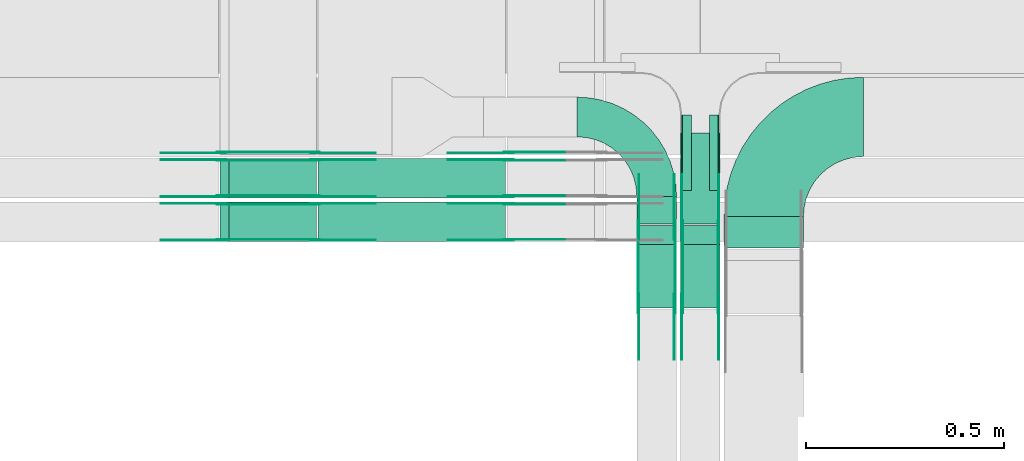
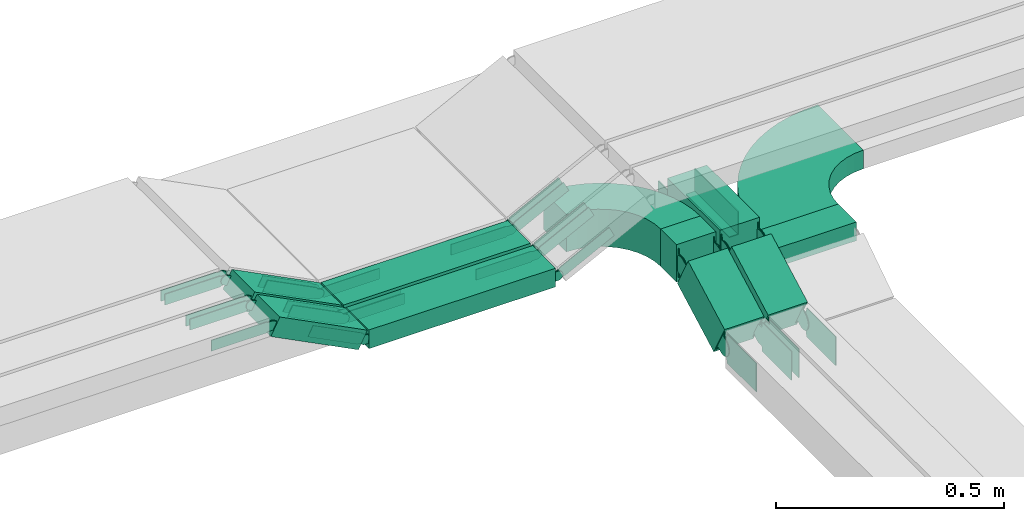
# One storey, part 22 of 28: 50 flow fittings, 9 flow segments.
"""IFC2X3 building model written with IfcOpenShell, lengths in millimetres."""

from ifc_helpers import new_model, entity, si_unit, converted_unit, derived_unit, direction, frame, frame_2d, origin, origin_2d_with_axis, place, context, subcontext, project, spatial, polyline, circle_curve, parameter, trimmed, segment, composite_curve, rectangle, outline, extrude, source, transform, mapped, material, type_object, type_shapes, element, save


model = new_model("IFC2X3")

# Units and contexts
model_context = context("Model", 3, precision=0.01, world=origin(), true_north=direction((6.12303176911189e-17, 1.0)))
body_context = subcontext(model_context, "Body", "Model", "MODEL_VIEW")
ifc_project = project(units=[si_unit("LENGTHUNIT", "METRE", prefix="MILLI"), si_unit("AREAUNIT", "SQUARE_METRE"), si_unit("VOLUMEUNIT", "CUBIC_METRE"), converted_unit("PLANEANGLEUNIT", "DEGREE", entity("IfcRatioMeasure", 0.0174532925199433), si_unit("PLANEANGLEUNIT", "RADIAN"), dimensions=[0, 0, 0, 0, 0, 0, 0]), si_unit("MASSUNIT", "GRAM", prefix="KILO"), derived_unit("MASSDENSITYUNIT", [(si_unit("MASSUNIT", "GRAM", prefix="KILO"), 1), (si_unit("LENGTHUNIT", "METRE"), -3)]), derived_unit("MOMENTOFINERTIAUNIT", [(si_unit("LENGTHUNIT", "METRE"), 4)]), si_unit("TIMEUNIT", "SECOND"), si_unit("FREQUENCYUNIT", "HERTZ"), si_unit("THERMODYNAMICTEMPERATUREUNIT", "DEGREE_CELSIUS"), derived_unit("THERMALTRANSMITTANCEUNIT", [(si_unit("MASSUNIT", "GRAM", prefix="KILO"), 1), (si_unit("THERMODYNAMICTEMPERATUREUNIT", "KELVIN"), -1), (si_unit("TIMEUNIT", "SECOND"), -3)]), derived_unit("VOLUMETRICFLOWRATEUNIT", [(si_unit("LENGTHUNIT", "METRE"), 3), (si_unit("TIMEUNIT", "SECOND"), -1)]), derived_unit("MASSFLOWRATEUNIT", [(si_unit("MASSUNIT", "GRAM", prefix="KILO"), 1), (si_unit("TIMEUNIT", "SECOND"), -1)]), derived_unit("ROTATIONALFREQUENCYUNIT", [(si_unit("TIMEUNIT", "SECOND"), -1)]), si_unit("ELECTRICCURRENTUNIT", "AMPERE"), si_unit("ELECTRICVOLTAGEUNIT", "VOLT"), si_unit("POWERUNIT", "WATT"), si_unit("FORCEUNIT", "NEWTON", prefix="KILO"), si_unit("ILLUMINANCEUNIT", "LUX"), si_unit("LUMINOUSFLUXUNIT", "LUMEN"), si_unit("LUMINOUSINTENSITYUNIT", "CANDELA"), derived_unit("USERDEFINED", [(si_unit("MASSUNIT", "GRAM", prefix="KILO"), -1), (si_unit("LENGTHUNIT", "METRE"), -2), (si_unit("TIMEUNIT", "SECOND"), 3), (si_unit("LUMINOUSFLUXUNIT", "LUMEN"), 1)]), derived_unit("LINEARVELOCITYUNIT", [(si_unit("LENGTHUNIT", "METRE"), 1), (si_unit("TIMEUNIT", "SECOND"), -1)]), si_unit("PRESSUREUNIT", "PASCAL"), derived_unit("USERDEFINED", [(si_unit("LENGTHUNIT", "METRE"), -2), (si_unit("MASSUNIT", "GRAM", prefix="KILO"), 1), (si_unit("TIMEUNIT", "SECOND"), -2)]), derived_unit("LINEARFORCEUNIT", [(si_unit("MASSUNIT", "GRAM", prefix="KILO"), 1), (si_unit("LENGTHUNIT", "METRE"), 1), (si_unit("TIMEUNIT", "SECOND"), -2), (si_unit("LENGTHUNIT", "METRE"), -1)]), derived_unit("PLANARFORCEUNIT", [(si_unit("MASSUNIT", "GRAM", prefix="KILO"), 1), (si_unit("LENGTHUNIT", "METRE"), 1), (si_unit("TIMEUNIT", "SECOND"), -2), (si_unit("LENGTHUNIT", "METRE"), -2)])], contexts=[model_context])

# Site, building, storey
site_placement = place(None, frame((0.0, -0.00077364408347762, 0.0)))
site = spatial("IfcSite", under=ifc_project, at=site_placement, CompositionType="ELEMENT")
building_placement = place(site_placement, origin())
building = spatial("IfcBuilding", under=site, at=building_placement, CompositionType="ELEMENT")
storey_placement = place(building_placement, origin())
storey = spatial("IfcBuildingStorey", under=building, at=storey_placement, CompositionType="ELEMENT", Elevation=0.0)

# Flow segments
cable_carrier_segment_type = type_object("IfcCableCarrierSegmentType", PredefinedType="CABLETRAYSEGMENT")
flow_segment_1_placement = place(storey_placement, frame((66224.9973266601, 8344.22814320413, 2600.0)))
element("IfcFlowSegment", 1, at=flow_segment_1_placement, inside=storey, type_object=cable_carrier_segment_type, context=body_context, shape_type="SweptSolid", body=[
    extrude(rectangle(XDim=69.0994138155711, YDim=99.9999999999946, at=origin_2d_with_axis()), frame((50.0, 34.5497069077856, 0.0), z_axis=(0.0, 0.0, 1.0), x_axis=(0.0, -1.0, 0.0)), (0.0, 0.0, 1.0), 100.0),
])
flow_segment_2_placement = place(storey_placement, frame((66224.9973266601, 8133.28255299691, 2512.93349487687)))
element("IfcFlowSegment", 2, at=flow_segment_2_placement, inside=storey, type_object=cable_carrier_segment_type, context=body_context, shape_type="SweptSolid", body=[
    extrude(rectangle(XDim=100.0, YDim=99.9999999999946, at=origin_2d_with_axis()), frame((50.0, 23.7298776139367, 44.0101455170004), z_axis=(0.0, 0.880202910340005, 0.474597552278754), x_axis=(0.0, -0.474597552278754, 0.880202910340005)), (0.0, 0.0, 1.0), 181.443664845643),
])
flow_segment_3_placement = place(storey_placement, frame((66334.9973266601, 8344.22814320465, 2600.0)))
element("IfcFlowSegment", 3, at=flow_segment_3_placement, inside=storey, type_object=cable_carrier_segment_type, context=body_context, shape_type="SweptSolid", body=[
    extrude(rectangle(XDim=230.099413815084, YDim=99.9999999999946, at=origin_2d_with_axis()), frame((50.0, 115.049706907542, 0.0), z_axis=(0.0, 0.0, 1.0), x_axis=(0.0, -1.0, 0.0)), (0.0, 0.0, 1.0), 100.0),
])
flow_segment_4_placement = place(storey_placement, frame((66334.9973266601, 8133.28255299713, 2512.93349487673)))
element("IfcFlowSegment", 4, at=flow_segment_4_placement, inside=storey, type_object=cable_carrier_segment_type, context=body_context, shape_type="SweptSolid", body=[
    extrude(rectangle(XDim=99.9999999999998, YDim=99.9999999999946, at=frame_2d((4.9382720135327e-13, 0.0), x_axis=(1.0, 0.0))), frame((50.0, 23.7298776137104, 44.0101455171233), z_axis=(0.0, 0.880202910342462, 0.474597552274198), x_axis=(0.0, -0.474597552274198, 0.880202910342462)), (0.0, 0.0, 1.0), 181.443664845729),
])
flow_segment_5_placement = place(storey_placement, frame((66444.9973266601, 8284.1246974401, 2600.0)))
element("IfcFlowSegment", 5, at=flow_segment_5_placement, inside=storey, type_object=cable_carrier_segment_type, context=body_context, shape_type="SweptSolid", body=[
    extrude(rectangle(XDim=79.2028595795973, YDim=200.000000000007, at=origin_2d_with_axis()), frame((100.0, 39.6014297898203, 0.0), z_axis=(0.0, 0.0, 1.0), x_axis=(0.0, -1.0, 0.0)), (0.0, 0.0, 1.0), 49.9999999999995),
])
flow_segment_6_placement = place(storey_placement, frame((65421.7807105328, 8300.00006103516, 2730.0)))
element("IfcFlowSegment", 6, at=flow_segment_6_placement, inside=storey, type_object=cable_carrier_segment_type, context=body_context, shape_type="SweptSolid", body=[
    extrude(rectangle(XDim=472.037715986993, YDim=100.000000000001, at=frame_2d((8.65441052155802e-12, 0.0), x_axis=(1.0, 0.0))), frame((236.018857993505, 50.0, 0.0), z_axis=(0.0, 0.0, 1.0), x_axis=(-1.0, 0.0, 0.0)), (0.0, 0.0, 1.0), 50.0000000000005),
])
flow_segment_7_placement = place(storey_placement, frame((65174.0498503685, 8300.00006103516, 2736.33963819349)))
element("IfcFlowSegment", 7, at=flow_segment_7_placement, inside=storey, type_object=cable_carrier_segment_type, context=body_context, shape_type="SweptSolid", body=[
    extrude(rectangle(XDim=50.0000000000027, YDim=99.9999999999989, at=frame_2d((-4.81392703477468e-13, 0.0), x_axis=(1.0, 0.0))), frame((11.3497624934895, 50.0, 135.045560508321), z_axis=(0.891006524188364, 0.0, -0.453990499739555), x_axis=(0.453990499739555, 0.0, 0.891006524188364)), (0.0, 0.0, 1.0), 248.39814372396),
])
flow_segment_8_placement = place(storey_placement, frame((65421.7807105328, 8410.0000610352, 2730.0)))
element("IfcFlowSegment", 8, at=flow_segment_8_placement, inside=storey, type_object=cable_carrier_segment_type, context=body_context, shape_type="SweptSolid", body=[
    extrude(rectangle(XDim=472.037715986993, YDim=99.9999999999989, at=frame_2d((8.65441052155802e-12, -1.08357767203415e-12), x_axis=(1.0, 0.0))), frame((236.018857993505, 50.0, 0.0), z_axis=(0.0, 0.0, 1.0), x_axis=(-1.0, 0.0, 0.0)), (0.0, 0.0, 1.0), 50.0000000000005),
])
flow_segment_9_placement = place(storey_placement, frame((65174.0498503684, 8410.0000610352, 2736.33963819349)))
element("IfcFlowSegment", 9, at=flow_segment_9_placement, inside=storey, type_object=cable_carrier_segment_type, context=body_context, shape_type="SweptSolid", body=[
    extrude(rectangle(XDim=49.9999999999978, YDim=100.000000000001, at=frame_2d((4.83169060316868e-13, 0.0), x_axis=(1.0, 0.0))), frame((11.3497624934895, 50.0, 135.04556050832), z_axis=(0.891006524188517, 0.0, -0.453990499739253), x_axis=(0.453990499739253, 0.0, 0.891006524188517)), (0.0, 0.0, 1.0), 248.398143724083),
])

# Flow fittings
ifc_material_1 = material(Name="G")
cable_carrier_fitting_type_1 = type_object("IfcCableCarrierFittingType", PredefinedType="NOTDEFINED", material=ifc_material_1)
shared_shape_1 = source(origin(), body_context, "Body", "SweptSolid", [
    extrude(outline(composite_curve([segment(trimmed(circle_curve(frame_2d((-44.5901162790698, 0.0), x_axis=(1.0, 0.0)), 12.5), [parameter(90.0000000000007)], [parameter(270.0)], True, "PARAMETER"), True, "CONTINUOUS"), segment(polyline([(-44.5901162790697, -12.5), (-33.0901162790698, -12.5)]), True, "CONTINUOUS"), segment(polyline([(-33.0901162790698, -12.5), (-31.2296511627907, -14.5)]), True, "CONTINUOUS"), segment(polyline([(-31.2296511627907, -14.5), (108.90988372093, -14.5)]), True, "CONTINUOUS"), segment(polyline([(108.90988372093, -14.5), (108.90988372093, 14.5)]), True, "CONTINUOUS"), segment(polyline([(108.90988372093, 14.5), (-31.2296511627907, 14.5)]), True, "CONTINUOUS"), segment(polyline([(-31.2296511627907, 14.5), (-33.0901162790698, 12.5)]), True, "CONTINUOUS"), segment(polyline([(-33.0901162790698, 12.5), (-44.5901162790699, 12.5)]), True, "CONTINUOUS")], self_intersect=False)), frame((44.5901162790698, 0.0, 0.0), z_axis=(0.0, 0.0, -1.0), x_axis=(1.0, 0.0, 0.0)), (0.0, 0.0, -1.0), 2.0),
])
type_shapes(cable_carrier_fitting_type_1, [shared_shape_1])
for number, where, z_axis, x_axis in (
    (10, (65901.780710533, 8395.46006104532, 2755.0), (0.0, 1.0, 0.0), (-1.0, 0.0, 0.0)),
    (11, (65413.8184265196, 8304.540061025, 2755.0), (0.0, -1.0, 0.0), (1.0, 0.0, 0.0)),
    (12, (65178.3051658588, 8304.540061025, 2875.0), (0.0, -1.0, 0.0), (-1.0, 0.0, 0.0)),
    (13, (65901.780710533, 8505.46006104536, 2755.0), (0.0, 1.0, 0.0), (-1.0, 0.0, 0.0)),
    (14, (65413.8184265196, 8414.54006102505, 2755.0), (0.0, -1.0, 0.0), (1.0, 0.0, 0.0)),
    (15, (65413.8184265196, 8524.54006102499, 2755.0), (0.0, -1.0, 0.0), (1.0, 0.0, 0.0)),
    (16, (65178.3051658586, 8524.54006102499, 2875.0), (0.0, -1.0, 0.0), (-1.0, 0.0, 0.0)),
    (17, (65178.3051658586, 8414.54006102505, 2875.0), (0.0, -1.0, 0.0), (-1.0, 0.0, 0.0)),
):
    element("IfcFlowFitting", number, at=place(storey_placement, frame(where, z_axis=z_axis, x_axis=x_axis)), inside=storey, type_object=cable_carrier_fitting_type_1, material=ifc_material_1, context=body_context, shape_type="MappedRepresentation", body=[
        mapped(shared_shape_1, transform((0.0, 0.0, 0.0), scale=1.0)),
    ])
cable_carrier_fitting_type_2 = type_object("IfcCableCarrierFittingType", PredefinedType="NOTDEFINED", material=ifc_material_1)
shared_shape_2 = source(origin(), body_context, "Body", "SweptSolid", [
    extrude(outline(composite_curve([segment(trimmed(circle_curve(frame_2d((-44.5901162790697, 0.0), x_axis=(1.0, 0.0)), 12.5), [parameter(90.0000000000007)], [parameter(270.0)], True, "PARAMETER"), True, "CONTINUOUS"), segment(polyline([(-44.5901162790697, -12.5), (-33.0901162790697, -12.5)]), True, "CONTINUOUS"), segment(polyline([(-33.0901162790697, -12.5), (-31.2296511627907, -14.5)]), True, "CONTINUOUS"), segment(polyline([(-31.2296511627907, -14.5), (108.90988372093, -14.5)]), True, "CONTINUOUS"), segment(polyline([(108.90988372093, -14.5), (108.90988372093, 14.5)]), True, "CONTINUOUS"), segment(polyline([(108.90988372093, 14.5), (-31.2296511627907, 14.5)]), True, "CONTINUOUS"), segment(polyline([(-31.2296511627907, 14.5), (-33.0901162790698, 12.5)]), True, "CONTINUOUS"), segment(polyline([(-33.0901162790698, 12.5), (-44.5901162790699, 12.5)]), True, "CONTINUOUS")], self_intersect=False)), frame((44.5901162790697, 0.0, 0.0)), (0.0, 0.0, 1.0), 2.0),
])
type_shapes(cable_carrier_fitting_type_2, [shared_shape_2])
for number, where, z_axis, x_axis in (
    (18, (65901.780710533, 8304.540061025, 2755.0), (0.0, -1.0, 0.0), (-1.0, 0.0, 0.0)),
    (19, (65413.8184265196, 8395.46006104532, 2755.0), (0.0, 1.0, 0.0), (1.0, 0.0, 0.0)),
    (20, (65178.3051658588, 8395.46006104532, 2875.0), (0.0, 1.0, 0.0), (-1.0, 0.0, 0.0)),
    (21, (65901.780710533, 8414.54006102504, 2755.0), (0.0, -1.0, 0.0), (-1.0, 0.0, 0.0)),
    (22, (65413.8184265196, 8505.46006104537, 2755.0), (0.0, 1.0, 0.0), (1.0, 0.0, 0.0)),
    (23, (65901.780710533, 8524.54006102499, 2755.0), (0.0, -1.0, 0.0), (-1.0, 0.0, 0.0)),
    (24, (65178.3051658586, 8505.46006104537, 2875.0), (0.0, 1.0, 0.0), (-1.0, 0.0, 0.0)),
):
    element("IfcFlowFitting", number, at=place(storey_placement, frame(where, z_axis=z_axis, x_axis=x_axis)), inside=storey, type_object=cable_carrier_fitting_type_2, material=ifc_material_1, context=body_context, shape_type="MappedRepresentation", body=[
        mapped(shared_shape_2, transform((0.0, 0.0, 0.0), scale=1.0)),
    ])
cable_carrier_fitting_type_3 = type_object("IfcCableCarrierFittingType", PredefinedType="NOTDEFINED", material=ifc_material_1)
shared_shape_3 = source(origin(), body_context, "Body", "SweptSolid", [
    extrude(outline(composite_curve([segment(trimmed(circle_curve(frame_2d((-44.5901162790698, 0.0), x_axis=(1.0, 0.0)), 12.5), [parameter(90.0000000000007)], [parameter(270.0)], True, "PARAMETER"), True, "CONTINUOUS"), segment(polyline([(-44.5901162790697, -12.5), (-33.0901162790698, -12.5)]), True, "CONTINUOUS"), segment(polyline([(-33.0901162790698, -12.5), (-31.2296511627907, -14.5)]), True, "CONTINUOUS"), segment(polyline([(-31.2296511627907, -14.5), (108.90988372093, -14.5)]), True, "CONTINUOUS"), segment(polyline([(108.90988372093, -14.5), (108.90988372093, 14.5)]), True, "CONTINUOUS"), segment(polyline([(108.90988372093, 14.5), (-31.2296511627907, 14.5)]), True, "CONTINUOUS"), segment(polyline([(-31.2296511627907, 14.5), (-33.0901162790698, 12.5)]), True, "CONTINUOUS"), segment(polyline([(-33.0901162790698, 12.5), (-44.5901162790699, 12.5)]), True, "CONTINUOUS")], self_intersect=False)), frame((44.5901162790698, 0.0, 0.0), z_axis=(0.0, 0.0, -1.0), x_axis=(1.0, 0.0, 0.0)), (0.0, 0.0, -1.0), 2.0),
])
type_shapes(cable_carrier_fitting_type_3, [shared_shape_3])
for number, where, z_axis, x_axis in (
    (25, (65901.780710533, 8306.540061025, 2755.0), (0.0, -1.0, 0.0), (0.891006524188259, 0.0, 0.45399049973976)),
    (26, (65413.8184265196, 8393.46006104532, 2755.0), (0.0, 1.0, 0.0), (-0.891006524188259, 0.0, 0.45399049973976)),
    (27, (65178.3051658588, 8393.46006104531, 2875.0), (0.0, 1.0, 0.0), (0.891006524188393, 0.0, -0.453990499739498)),
    (28, (65901.780710533, 8416.54006102505, 2755.0), (0.0, -1.0, 0.0), (0.891006524188259, 0.0, 0.45399049973976)),
    (29, (65413.8184265196, 8503.46006104537, 2755.0), (0.0, 1.0, 0.0), (-0.891006524188259, 0.0, 0.45399049973976)),
    (30, (65901.780710533, 8526.54006102499, 2755.0), (0.0, -1.0, 0.0), (0.891006524188259, 0.0, 0.45399049973976)),
    (31, (65178.3051658586, 8503.46006104537, 2875.0), (0.0, 1.0, 0.0), (0.891006524188516, 0.0, -0.453990499739256)),
):
    element("IfcFlowFitting", number, at=place(storey_placement, frame(where, z_axis=z_axis, x_axis=x_axis)), inside=storey, type_object=cable_carrier_fitting_type_3, material=ifc_material_1, context=body_context, shape_type="MappedRepresentation", body=[
        mapped(shared_shape_3, transform((0.0, 0.0, 0.0), scale=1.0)),
    ])
cable_carrier_fitting_type_4 = type_object("IfcCableCarrierFittingType", PredefinedType="NOTDEFINED", material=ifc_material_1)
shared_shape_4 = source(origin(), body_context, "Body", "SweptSolid", [
    extrude(outline(composite_curve([segment(trimmed(circle_curve(frame_2d((-44.5901162790697, 0.0), x_axis=(1.0, 0.0)), 12.5), [parameter(90.0000000000007)], [parameter(270.0)], True, "PARAMETER"), True, "CONTINUOUS"), segment(polyline([(-44.5901162790697, -12.5), (-33.0901162790697, -12.5)]), True, "CONTINUOUS"), segment(polyline([(-33.0901162790697, -12.5), (-31.2296511627907, -14.5)]), True, "CONTINUOUS"), segment(polyline([(-31.2296511627907, -14.5), (108.90988372093, -14.5)]), True, "CONTINUOUS"), segment(polyline([(108.90988372093, -14.5), (108.90988372093, 14.5)]), True, "CONTINUOUS"), segment(polyline([(108.90988372093, 14.5), (-31.2296511627907, 14.5)]), True, "CONTINUOUS"), segment(polyline([(-31.2296511627907, 14.5), (-33.0901162790698, 12.5)]), True, "CONTINUOUS"), segment(polyline([(-33.0901162790698, 12.5), (-44.5901162790699, 12.5)]), True, "CONTINUOUS")], self_intersect=False)), frame((44.5901162790697, 0.0, 0.0)), (0.0, 0.0, 1.0), 2.0),
])
type_shapes(cable_carrier_fitting_type_4, [shared_shape_4])
for number, where, z_axis, x_axis in (
    (32, (65901.780710533, 8393.46006104531, 2755.0), (0.0, 1.0, 0.0), (0.891006524188259, 0.0, 0.45399049973976)),
    (33, (65413.8184265196, 8306.540061025, 2755.0), (0.0, -1.0, 0.0), (-0.891006524188259, 0.0, 0.45399049973976)),
    (34, (65178.3051658588, 8306.540061025, 2875.0), (0.0, -1.0, 0.0), (0.891006524188393, 0.0, -0.453990499739498)),
    (35, (65901.780710533, 8503.46006104536, 2755.0), (0.0, 1.0, 0.0), (0.891006524188259, 0.0, 0.45399049973976)),
    (36, (65413.8184265196, 8416.54006102505, 2755.0), (0.0, -1.0, 0.0), (-0.891006524188259, 0.0, 0.45399049973976)),
    (37, (65413.8184265196, 8526.54006102499, 2755.0), (0.0, -1.0, 0.0), (-0.891006524188259, 0.0, 0.45399049973976)),
    (38, (65178.3051658586, 8526.54006102499, 2875.0), (0.0, -1.0, 0.0), (0.891006524188515, 0.0, -0.453990499739259)),
    (39, (65178.3051658586, 8416.54006102505, 2875.0), (0.0, -1.0, 0.0), (0.891006524188516, 0.0, -0.453990499739256)),
):
    element("IfcFlowFitting", number, at=place(storey_placement, frame(where, z_axis=z_axis, x_axis=x_axis)), inside=storey, type_object=cable_carrier_fitting_type_4, material=ifc_material_1, context=body_context, shape_type="MappedRepresentation", body=[
        mapped(shared_shape_4, transform((0.0, 0.0, 0.0), scale=1.0)),
    ])
cable_carrier_fitting_type_5 = type_object("IfcCableCarrierFittingType", PredefinedType="NOTDEFINED", material=ifc_material_1)
shared_shape_5 = source(origin(), body_context, "Body", "SweptSolid", [
    extrude(outline(composite_curve([segment(trimmed(circle_curve(frame_2d((-41.4651162790697, 0.0), x_axis=(1.0, 0.0)), 25.0), [parameter(90.0000000000007)], [parameter(270.0)], True, "PARAMETER"), True, "CONTINUOUS"), segment(polyline([(-41.4651162790697, -25.0), (-29.9651162790697, -25.0)]), True, "CONTINUOUS"), segment(polyline([(-29.9651162790697, -25.0), (-28.1046511627907, -38.5)]), True, "CONTINUOUS"), segment(polyline([(-28.1046511627907, -38.5), (99.5348837209303, -38.5)]), True, "CONTINUOUS"), segment(polyline([(99.5348837209303, -38.5), (99.5348837209303, 38.5)]), True, "CONTINUOUS"), segment(polyline([(99.5348837209303, 38.5), (-28.1046511627907, 38.5)]), True, "CONTINUOUS"), segment(polyline([(-28.1046511627907, 38.5), (-29.9651162790697, 25.0)]), True, "CONTINUOUS"), segment(polyline([(-29.9651162790697, 25.0), (-41.46511627907, 25.0)]), True, "CONTINUOUS")], self_intersect=False)), frame((41.4651162790697, 0.0, 0.0), z_axis=(0.0, 0.0, -1.0), x_axis=(1.0, 0.0, 0.0)), (0.0, 0.0, -1.0), 2.0),
])
type_shapes(cable_carrier_fitting_type_5, [shared_shape_5])
for number, where, z_axis, x_axis in (
    (40, (66320.4573266703, 8329.59755701468, 2650.0), (1.0, 0.0, 0.0), (0.0, -0.880202910340009, -0.474597552278748)),
    (41, (66320.4573266703, 8144.13454606691, 2550.0), (1.0, 0.0, 0.0), (0.0, 0.880202910340009, 0.474597552278748)),
    (42, (66339.53732665, 8329.59755701518, 2650.0), (-1.0, 0.0, 0.0), (0.0, 1.0, 0.0)),
    (43, (66339.53732665, 8144.13454606691, 2550.0), (-1.0, 0.0, 0.0), (0.0, -1.0, 0.0)),
):
    element("IfcFlowFitting", number, at=place(storey_placement, frame(where, z_axis=z_axis, x_axis=x_axis)), inside=storey, type_object=cable_carrier_fitting_type_5, material=ifc_material_1, context=body_context, shape_type="MappedRepresentation", body=[
        mapped(shared_shape_5, transform((0.0, 0.0, 0.0), scale=1.0)),
    ])
cable_carrier_fitting_type_6 = type_object("IfcCableCarrierFittingType", PredefinedType="NOTDEFINED", material=ifc_material_1)
shared_shape_6 = source(origin(), body_context, "Body", "SweptSolid", [
    extrude(outline(composite_curve([segment(trimmed(circle_curve(frame_2d((-41.4651162790697, 0.0), x_axis=(1.0, 0.0)), 25.0), [parameter(90.0000000000007)], [parameter(270.0)], True, "PARAMETER"), True, "CONTINUOUS"), segment(polyline([(-41.4651162790697, -25.0), (-29.9651162790697, -25.0)]), True, "CONTINUOUS"), segment(polyline([(-29.9651162790697, -25.0), (-28.1046511627907, -38.5)]), True, "CONTINUOUS"), segment(polyline([(-28.1046511627907, -38.5), (99.5348837209303, -38.5)]), True, "CONTINUOUS"), segment(polyline([(99.5348837209303, -38.5), (99.5348837209303, 38.5)]), True, "CONTINUOUS"), segment(polyline([(99.5348837209303, 38.5), (-28.1046511627907, 38.5)]), True, "CONTINUOUS"), segment(polyline([(-28.1046511627907, 38.5), (-29.9651162790697, 25.0)]), True, "CONTINUOUS"), segment(polyline([(-29.9651162790697, 25.0), (-41.46511627907, 25.0)]), True, "CONTINUOUS")], self_intersect=False)), frame((41.4651162790697, 0.0, 0.0)), (0.0, 0.0, 1.0), 2.0),
])
type_shapes(cable_carrier_fitting_type_6, [shared_shape_6])
for number, where, z_axis, x_axis in (
    (44, (66229.53732665, 8329.59755701468, 2650.0), (-1.0, 0.0, 0.0), (0.0, -0.880202910340009, -0.474597552278748)),
    (45, (66229.53732665, 8144.1345460669, 2550.0), (-1.0, 0.0, 0.0), (0.0, 0.880202910340009, 0.474597552278748)),
    (46, (66430.4573266703, 8329.59755701518, 2650.0), (1.0, 0.0, 0.0), (0.0, 1.0, 0.0)),
    (47, (66430.4573266703, 8144.13454606691, 2550.0), (1.0, 0.0, 0.0), (0.0, -1.0, 0.0)),
):
    element("IfcFlowFitting", number, at=place(storey_placement, frame(where, z_axis=z_axis, x_axis=x_axis)), inside=storey, type_object=cable_carrier_fitting_type_6, material=ifc_material_1, context=body_context, shape_type="MappedRepresentation", body=[
        mapped(shared_shape_6, transform((0.0, 0.0, 0.0), scale=1.0)),
    ])
cable_carrier_fitting_type_7 = type_object("IfcCableCarrierFittingType", PredefinedType="NOTDEFINED", material=ifc_material_1)
shared_shape_7 = source(origin(), body_context, "Body", "SweptSolid", [
    extrude(outline(composite_curve([segment(trimmed(circle_curve(frame_2d((-41.4651162790697, 0.0), x_axis=(1.0, 0.0)), 25.0), [parameter(90.0000000000007)], [parameter(270.0)], True, "PARAMETER"), True, "CONTINUOUS"), segment(polyline([(-41.4651162790697, -25.0), (-29.9651162790697, -25.0)]), True, "CONTINUOUS"), segment(polyline([(-29.9651162790697, -25.0), (-28.1046511627907, -38.5)]), True, "CONTINUOUS"), segment(polyline([(-28.1046511627907, -38.5), (99.5348837209303, -38.5)]), True, "CONTINUOUS"), segment(polyline([(99.5348837209303, -38.5), (99.5348837209303, 38.5)]), True, "CONTINUOUS"), segment(polyline([(99.5348837209303, 38.5), (-28.1046511627907, 38.5)]), True, "CONTINUOUS"), segment(polyline([(-28.1046511627907, 38.5), (-29.9651162790697, 25.0)]), True, "CONTINUOUS"), segment(polyline([(-29.9651162790697, 25.0), (-41.46511627907, 25.0)]), True, "CONTINUOUS")], self_intersect=False)), frame((41.4651162790697, 0.0, 0.0), z_axis=(0.0, 0.0, -1.0), x_axis=(1.0, 0.0, 0.0)), (0.0, 0.0, -1.0), 2.0),
])
type_shapes(cable_carrier_fitting_type_7, [shared_shape_7])
for number, where, z_axis, x_axis in (
    (48, (66231.53732665, 8329.59755701467, 2650.0), (-1.0, 0.0, 0.0), (0.0, 1.0, 0.0)),
    (49, (66231.53732665, 8144.13454606691, 2550.0), (-1.0, 0.0, 0.0), (0.0, -1.0, 0.0)),
    (50, (66428.4573266703, 8329.59755701519, 2650.0), (1.0, 0.0, 0.0), (0.0, -0.880202910340133, -0.474597552278517)),
    (51, (66428.4573266703, 8144.1345460669, 2550.0), (1.0, 0.0, 0.0), (0.0, 0.880202910340084, 0.474597552278608)),
):
    element("IfcFlowFitting", number, at=place(storey_placement, frame(where, z_axis=z_axis, x_axis=x_axis)), inside=storey, type_object=cable_carrier_fitting_type_7, material=ifc_material_1, context=body_context, shape_type="MappedRepresentation", body=[
        mapped(shared_shape_7, transform((0.0, 0.0, 0.0), scale=1.0)),
    ])
cable_carrier_fitting_type_8 = type_object("IfcCableCarrierFittingType", PredefinedType="NOTDEFINED", material=ifc_material_1)
shared_shape_8 = source(origin(), body_context, "Body", "SweptSolid", [
    extrude(outline(composite_curve([segment(trimmed(circle_curve(frame_2d((-41.4651162790697, 0.0), x_axis=(1.0, 0.0)), 25.0), [parameter(90.0000000000007)], [parameter(270.0)], True, "PARAMETER"), True, "CONTINUOUS"), segment(polyline([(-41.4651162790697, -25.0), (-29.9651162790697, -25.0)]), True, "CONTINUOUS"), segment(polyline([(-29.9651162790697, -25.0), (-28.1046511627907, -38.5)]), True, "CONTINUOUS"), segment(polyline([(-28.1046511627907, -38.5), (99.5348837209303, -38.5)]), True, "CONTINUOUS"), segment(polyline([(99.5348837209303, -38.5), (99.5348837209303, 38.5)]), True, "CONTINUOUS"), segment(polyline([(99.5348837209303, 38.5), (-28.1046511627907, 38.5)]), True, "CONTINUOUS"), segment(polyline([(-28.1046511627907, 38.5), (-29.9651162790697, 25.0)]), True, "CONTINUOUS"), segment(polyline([(-29.9651162790697, 25.0), (-41.46511627907, 25.0)]), True, "CONTINUOUS")], self_intersect=False)), frame((41.4651162790697, 0.0, 0.0)), (0.0, 0.0, 1.0), 2.0),
])
type_shapes(cable_carrier_fitting_type_8, [shared_shape_8])
for number, where, z_axis, x_axis in (
    (52, (66318.4573266703, 8329.59755701467, 2650.0), (1.0, 0.0, 0.0), (0.0, 1.0, 0.0)),
    (53, (66318.4573266703, 8144.13454606691, 2550.0), (1.0, 0.0, 0.0), (0.0, -1.0, 0.0)),
    (54, (66341.53732665, 8329.59755701519, 2650.0), (-1.0, 0.0, 0.0), (0.0, -0.880202910340133, -0.474597552278517)),
    (55, (66341.53732665, 8144.1345460669, 2550.0), (-1.0, 0.0, 0.0), (0.0, 0.880202910340084, 0.474597552278608)),
):
    element("IfcFlowFitting", number, at=place(storey_placement, frame(where, z_axis=z_axis, x_axis=x_axis)), inside=storey, type_object=cable_carrier_fitting_type_8, material=ifc_material_1, context=body_context, shape_type="MappedRepresentation", body=[
        mapped(shared_shape_8, transform((0.0, 0.0, 0.0), scale=1.0)),
    ])
ifc_material_2 = material()
cable_carrier_fitting_type_9 = type_object("IfcCableCarrierFittingType", PredefinedType="NOTDEFINED", material=ifc_material_2)
shared_shape_9 = source(origin(), body_context, "Body", "SweptSolid", [
    extrude(outline(polyline([(-9.16666666666668, -21.5000000000001), (15.8333333333333, -21.5000000000001), (15.8333333333333, -19.0), (-6.66666666666664, -19.0), (-6.66666666666664, 40.5), (-9.16666666666668, 40.5), (-9.16666666666668, -21.5000000000001)])), frame((-95.0, 9.16666666666668, -26.0), z_axis=(1.0, 0.0, 0.0), x_axis=(0.0, 1.0, 0.0)), (0.0, 0.0, 1.0), 190.0),
])
type_shapes(cable_carrier_fitting_type_9, [shared_shape_9])
for number, where, z_axis, x_axis in (
    (56, (66432.4973266601, 8524.32755701973, 2650.0), (0.0, 0.0, 1.0), (0.0, 1.0, 0.0)),
    (57, (66337.4973266601, 8524.32755701973, 2650.0), (0.0, 0.0, 1.0), (0.0, -1.0, 0.0)),
):
    element("IfcFlowFitting", number, at=place(storey_placement, frame(where, z_axis=z_axis, x_axis=x_axis)), inside=storey, type_object=cable_carrier_fitting_type_9, material=ifc_material_2, context=body_context, shape_type="MappedRepresentation", body=[
        mapped(shared_shape_9, transform((0.0, 0.0, 0.0), scale=1.0)),
    ])
ifc_material_3 = material()
cable_carrier_fitting_type_10 = type_object("IfcCableCarrierFittingType", Name="470_DKC_S5_Variable Angle Elbow 0-45:-", PredefinedType="NOTDEFINED", material=ifc_material_3)
shared_shape_10 = source(origin(), body_context, "Body", "SweptSolid", [
    extrude(outline(composite_curve([segment(polyline([(-100.749999999999, -150.250000000001), (-99.7499999999981, -150.250000000001)]), True, "CONTINUOUS"), segment(trimmed(circle_curve(frame_2d((-99.7500000000006, 99.7499999999987), x_axis=(0.0, -1.0)), 250.0), [parameter(0.0)], [parameter(90.0000000000001)], True, "PARAMETER"), True, "CONTINUOUS"), segment(polyline([(150.249999999999, 99.7500000000013), (150.249999999999, 100.750000000001)]), True, "CONTINUOUS"), segment(polyline([(150.249999999999, 100.750000000001), (50.2499999999992, 100.750000000001)]), True, "CONTINUOUS"), segment(polyline([(50.2499999999992, 100.750000000001), (50.2499999999992, 99.7500000000002)]), True, "CONTINUOUS"), segment(trimmed(circle_curve(frame_2d((-99.7500000000006, 99.7499999999987), x_axis=(0.0, -1.0)), 150.0), [parameter(0.0)], [parameter(90.0000000000001)], True, "PARAMETER"), False, "CONTINUOUS"), segment(polyline([(-99.7499999999989, -50.2500000000011), (-100.75, -50.2500000000011)]), True, "CONTINUOUS"), segment(polyline([(-100.75, -50.2500000000011), (-100.749999999999, -150.250000000001)]), True, "CONTINUOUS")], self_intersect=False)), frame((-100.249999999991, 100.249999999992, -50.0)), (0.0, 0.0, 1.0), 100.0),
])
type_shapes(cable_carrier_fitting_type_10, [shared_shape_10])
flow_fitting_1_placement = place(storey_placement, frame((66274.9973266601, 8614.32755701969, 2650.0), z_axis=(0.0, 0.0, 1.0), x_axis=(0.0, 1.0, 0.0)))
element("IfcFlowFitting", 58, at=flow_fitting_1_placement, inside=storey, type_object=cable_carrier_fitting_type_10, material=ifc_material_3, Name="470_DKC_S5_Variable Angle Elbow 0-45:-", ObjectType="470_DKC_S5_Variable Angle Elbow 0-45:-", context=body_context, shape_type="MappedRepresentation", body=[
    mapped(shared_shape_10, transform((0.0, 0.0, 0.0), scale=1.0)),
])
cable_carrier_fitting_type_11 = type_object("IfcCableCarrierFittingType", Name="470_DKC_S5_Variable Angle Elbow 0-45:-", PredefinedType="NOTDEFINED", material=ifc_material_3)
shared_shape_11 = source(origin(), body_context, "Body", "SweptSolid", [
    extrude(outline(composite_curve([segment(polyline([(-125.750000000004, -225.249999999998), (-124.750000000003, -225.249999999998)]), True, "CONTINUOUS"), segment(trimmed(circle_curve(frame_2d((-124.749999999998, 124.750000000002), x_axis=(0.0, -1.0)), 350.0), [parameter(0.0)], [parameter(90.0000000000001)], True, "PARAMETER"), True, "CONTINUOUS"), segment(polyline([(225.250000000002, 124.749999999996), (225.250000000002, 125.749999999995)]), True, "CONTINUOUS"), segment(polyline([(225.250000000002, 125.749999999995), (25.2500000000021, 125.750000000001)]), True, "CONTINUOUS"), segment(polyline([(25.2500000000021, 125.750000000001), (25.2500000000021, 124.749999999999)]), True, "CONTINUOUS"), segment(trimmed(circle_curve(frame_2d((-124.749999999998, 124.750000000002), x_axis=(0.0, -1.0)), 150.0), [parameter(0.0)], [parameter(90.0000000000001)], True, "PARAMETER"), False, "CONTINUOUS"), segment(polyline([(-124.75, -25.2499999999982), (-125.750000000001, -25.2499999999981)]), True, "CONTINUOUS"), segment(polyline([(-125.750000000001, -25.2499999999981), (-125.750000000004, -225.249999999998)]), True, "CONTINUOUS")], self_intersect=False)), frame((-125.249999999991, 125.249999999992, -25.0)), (0.0, 0.0, 1.0), 50.000000000001),
])
type_shapes(cable_carrier_fitting_type_11, [shared_shape_11])
flow_fitting_2_placement = place(storey_placement, frame((66544.9973266601, 8614.3275570197, 2625.0), z_axis=(0.0, 0.0, 1.0), x_axis=(-1.0, 0.0, 0.0)))
element("IfcFlowFitting", 59, at=flow_fitting_2_placement, inside=storey, type_object=cable_carrier_fitting_type_11, material=ifc_material_3, Name="470_DKC_S5_Variable Angle Elbow 0-45:-", ObjectType="470_DKC_S5_Variable Angle Elbow 0-45:-", context=body_context, shape_type="MappedRepresentation", body=[
    mapped(shared_shape_11, transform((0.0, 0.0, 0.0), scale=1.0)),
])

save(model, "model.ifc")
